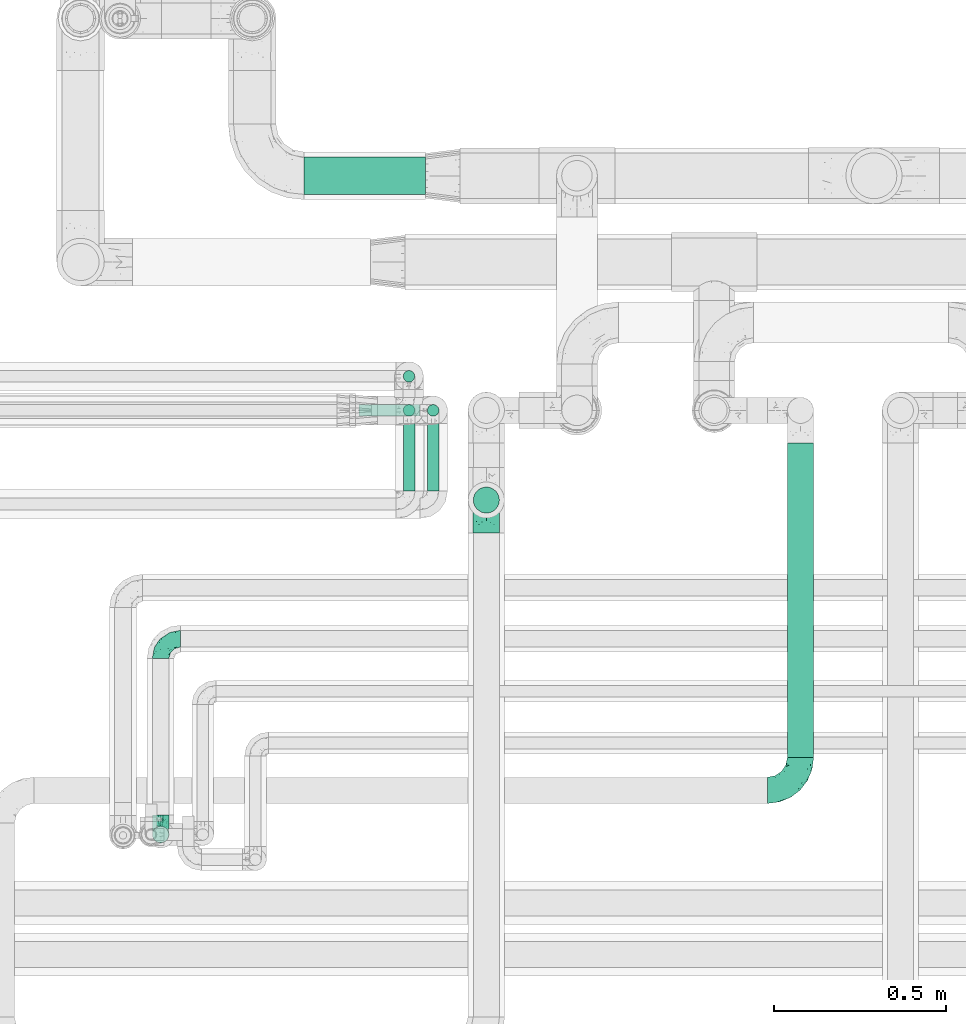
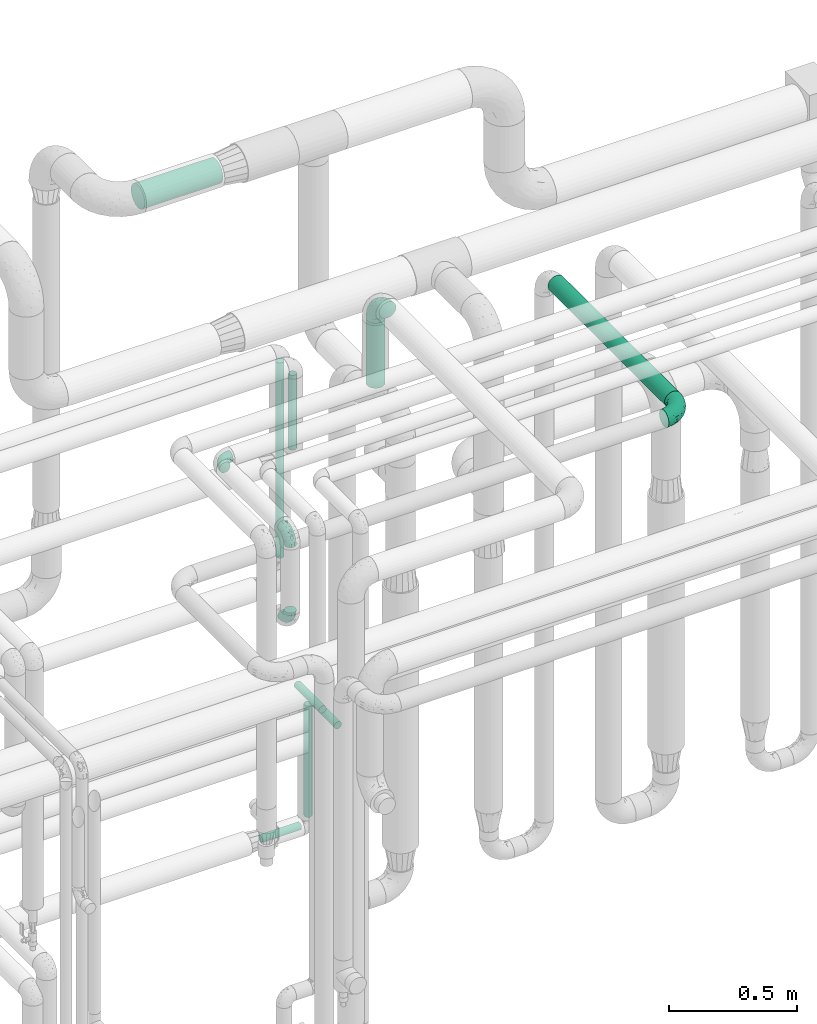
# One storey, part 703 of 827: 9 flow segments, 5 flow fittings.
"""IFC2X3 building model written with IfcOpenShell, lengths in millimetres."""

from ifc_helpers import new_model, entity, si_unit, converted_unit, derived_unit, direction, frame, origin, origin_2d_with_axis, place, context, subcontext, project, spatial, circle, extrude, faceted_brep, source, transform, mapped, material, type_object, type_shapes, element, save


model = new_model("IFC2X3")

# Units and contexts
model_context = context("Model", 3, precision=0.01, world=origin(), true_north=direction((6.12303176911189e-17, 1.0)))
body_context = subcontext(model_context, "Body", "Model", "MODEL_VIEW")
ifc_project = project(units=[si_unit("LENGTHUNIT", "METRE", prefix="MILLI"), si_unit("AREAUNIT", "SQUARE_METRE"), si_unit("VOLUMEUNIT", "CUBIC_METRE"), converted_unit("PLANEANGLEUNIT", "DEGREE", entity("IfcRatioMeasure", 0.0174532925199433), si_unit("PLANEANGLEUNIT", "RADIAN"), dimensions=[0, 0, 0, 0, 0, 0, 0]), si_unit("MASSUNIT", "GRAM", prefix="KILO"), derived_unit("MASSDENSITYUNIT", [(si_unit("MASSUNIT", "GRAM", prefix="KILO"), 1), (si_unit("LENGTHUNIT", "METRE"), -3)]), derived_unit("MOMENTOFINERTIAUNIT", [(si_unit("LENGTHUNIT", "METRE"), 4)]), si_unit("TIMEUNIT", "SECOND"), si_unit("FREQUENCYUNIT", "HERTZ"), si_unit("THERMODYNAMICTEMPERATUREUNIT", "DEGREE_CELSIUS"), derived_unit("THERMALTRANSMITTANCEUNIT", [(si_unit("MASSUNIT", "GRAM", prefix="KILO"), 1), (si_unit("THERMODYNAMICTEMPERATUREUNIT", "KELVIN"), -1), (si_unit("TIMEUNIT", "SECOND"), -3)]), derived_unit("VOLUMETRICFLOWRATEUNIT", [(si_unit("LENGTHUNIT", "METRE"), 3), (si_unit("TIMEUNIT", "SECOND"), -1)]), derived_unit("MASSFLOWRATEUNIT", [(si_unit("MASSUNIT", "GRAM", prefix="KILO"), 1), (si_unit("TIMEUNIT", "SECOND"), -1)]), derived_unit("ROTATIONALFREQUENCYUNIT", [(si_unit("TIMEUNIT", "SECOND"), -1)]), si_unit("ELECTRICCURRENTUNIT", "AMPERE"), si_unit("ELECTRICVOLTAGEUNIT", "VOLT"), si_unit("POWERUNIT", "WATT"), si_unit("FORCEUNIT", "NEWTON", prefix="KILO"), si_unit("ILLUMINANCEUNIT", "LUX"), si_unit("LUMINOUSFLUXUNIT", "LUMEN"), si_unit("LUMINOUSINTENSITYUNIT", "CANDELA"), derived_unit("USERDEFINED", [(si_unit("MASSUNIT", "GRAM", prefix="KILO"), -1), (si_unit("LENGTHUNIT", "METRE"), -2), (si_unit("TIMEUNIT", "SECOND"), 3), (si_unit("LUMINOUSFLUXUNIT", "LUMEN"), 1)]), derived_unit("LINEARVELOCITYUNIT", [(si_unit("LENGTHUNIT", "METRE"), 1), (si_unit("TIMEUNIT", "SECOND"), -1)]), si_unit("PRESSUREUNIT", "PASCAL"), derived_unit("USERDEFINED", [(si_unit("LENGTHUNIT", "METRE"), -2), (si_unit("MASSUNIT", "GRAM", prefix="KILO"), 1), (si_unit("TIMEUNIT", "SECOND"), -2)]), derived_unit("LINEARFORCEUNIT", [(si_unit("MASSUNIT", "GRAM", prefix="KILO"), 1), (si_unit("LENGTHUNIT", "METRE"), 1), (si_unit("TIMEUNIT", "SECOND"), -2), (si_unit("LENGTHUNIT", "METRE"), -1)]), derived_unit("PLANARFORCEUNIT", [(si_unit("MASSUNIT", "GRAM", prefix="KILO"), 1), (si_unit("LENGTHUNIT", "METRE"), 1), (si_unit("TIMEUNIT", "SECOND"), -2), (si_unit("LENGTHUNIT", "METRE"), -2)])], contexts=[model_context])

# Site, building, storey
site_placement = place(None, origin())
site = spatial("IfcSite", under=ifc_project, at=site_placement, CompositionType="ELEMENT")
building_placement = place(site_placement, origin())
building = spatial("IfcBuilding", under=site, at=building_placement, CompositionType="ELEMENT")
storey_placement = place(building_placement, frame((0.0, 0.0, 28200.0)))
storey = spatial("IfcBuildingStorey", under=building, at=storey_placement, Name="08", CompositionType="ELEMENT", Elevation=28200.0)

# Flow segments
pipe_segment_type_1 = type_object("IfcPipeSegmentType", PredefinedType="NOTDEFINED")
flow_segment_1_placement = place(storey_placement, frame((56258.55, 18124.5, 3444.15)))
element("IfcFlowSegment", 1, at=flow_segment_1_placement, inside=storey, type_object=pipe_segment_type_1, context=body_context, shape_type="SweptSolid", body=[
    extrude(circle(Radius=54.0, at=origin_2d_with_axis()), frame((0.0, 55.6, 55.6), z_axis=(1.0, 0.0, 0.0), x_axis=(0.0, 1.0, 0.0)), (0.0, 0.0, 1.0), 352.499999999972),
])
pipe_segment_type_2 = type_object("IfcPipeSegmentType", PredefinedType="NOTDEFINED")
flow_segment_2_placement = place(storey_placement, frame((57658.79, 16493.62, 3010.65)))
element("IfcFlowSegment", 2, at=flow_segment_2_placement, inside=storey, type_object=pipe_segment_type_2, context=body_context, shape_type="SweptSolid", body=[
    extrude(circle(Radius=37.75, at=origin_2d_with_axis()), frame((39.35, 0.0, 39.35), z_axis=(0.0, 1.0, 0.0), x_axis=(-1.0, 0.0, 0.0)), (0.0, 0.0, 1.0), 911.38356635599),
])
flow_segment_3_placement = place(storey_placement, frame((56544.88, 17580.47, 2030.5)))
element("IfcFlowSegment", 3, at=flow_segment_3_placement, inside=storey, type_object=pipe_segment_type_2, context=body_context, shape_type="SweptSolid", body=[
    extrude(circle(Radius=16.75, at=origin_2d_with_axis()), frame((18.35, 18.35, 0.0)), (0.0, 0.0, 1.0), 931.586150798507),
])
flow_segment_4_placement = place(storey_placement, frame((56544.88, 17481.65, 2605.5)))
element("IfcFlowSegment", 4, at=flow_segment_4_placement, inside=storey, type_object=pipe_segment_type_2, context=body_context, shape_type="SweptSolid", body=[
    extrude(circle(Radius=16.75, at=origin_2d_with_axis()), frame((18.35, 18.35, 0.0)), (0.0, 0.0, 1.0), 356.499999999793),
])
for number, where in (
    (5, (56545.88, 17266.56, 1481.65)),
    (6, (56614.88, 17266.56, 1381.65)),
):
    element("IfcFlowSegment", number, at=place(storey_placement, frame(where)), inside=storey, type_object=pipe_segment_type_2, context=body_context, shape_type="SweptSolid", body=[
        extrude(circle(Radius=16.75, at=origin_2d_with_axis()), frame((18.35, 0.0, 18.35), z_axis=(0.0, 1.0, 0.0), x_axis=(1.0, 0.0, 0.0)), (0.0, 0.0, 1.0), 195.438135542264),
    ])
flow_segment_5_placement = place(storey_placement, frame((56614.88, 17481.65, 830.5)))
element("IfcFlowSegment", 7, at=flow_segment_5_placement, inside=storey, type_object=pipe_segment_type_2, context=body_context, shape_type="SweptSolid", body=[
    extrude(circle(Radius=16.75, at=origin_2d_with_axis()), frame((18.35, 18.35, 0.0)), (0.0, 0.0, 1.0), 531.500000000009),
])
flow_segment_6_placement = place(storey_placement, frame((56418.23, 17481.65, 774.15)))
element("IfcFlowSegment", 8, at=flow_segment_6_placement, inside=storey, type_object=pipe_segment_type_2, context=body_context, shape_type="SweptSolid", body=[
    extrude(circle(Radius=16.75, at=origin_2d_with_axis()), frame((0.0, 18.35, 18.35), z_axis=(1.0, 0.0, 0.0), x_axis=(0.0, 1.0, 0.0)), (0.0, 0.0, 1.0), 177.00000000002),
])
flow_segment_7_placement = place(storey_placement, frame((56748.04, 17200.65, 2995.0)))
element("IfcFlowSegment", 9, at=flow_segment_7_placement, inside=storey, type_object=pipe_segment_type_2, context=body_context, shape_type="SweptSolid", body=[
    extrude(circle(Radius=37.75, at=origin_2d_with_axis()), frame((39.35, 39.35, 0.0)), (0.0, 0.0, 1.0), 309.999999999999),
])

# Flow fittings
ifc_material = material()
pipe_fitting_type_1 = type_object("IfcPipeFittingType", Name="ADSK_1", PredefinedType="NOTDEFINED", material=ifc_material)
shared_shape_1 = source(origin(), body_context, "Body", "Brep", [
    faceted_brep([(-57.0, 12.07, -20.91), (-57.0, 6.25, -23.33), (-57.0, 0.0, -24.15), (-57.0, -6.25, -23.33), (-57.0, -12.08, -20.91), (-57.0, -17.08, -17.08), (-57.0, -20.91, -12.08), (-57.0, -23.33, -6.25), (-57.0, -24.15, 0.0), (-57.0, -23.33, 6.25), (-57.0, -20.91, 12.07), (-57.0, -17.08, 17.08), (-57.0, -12.08, 20.91), (-57.0, -6.25, 23.33), (-57.0, 0.0, 24.15), (-57.0, 6.25, 23.33), (-57.0, 12.07, 20.91), (-57.0, 17.08, 17.08), (-57.0, 20.91, 12.07), (-57.0, 23.33, 6.25), (-57.0, 24.15, 0.0), (-57.0, 23.33, -6.25), (-57.0, 20.91, -12.08), (-57.0, 17.08, -17.08), (0.0, 57.0, -24.15), (-6.25, 57.0, -23.33), (-12.07, 57.0, -20.91), (-17.08, 57.0, -17.08), (-20.91, 57.0, -12.08), (-23.33, 57.0, -6.25), (-24.15, 57.0, 0.0), (-23.33, 57.0, 6.25), (-20.91, 57.0, 12.07), (-17.08, 57.0, 17.08), (-12.07, 57.0, 20.91), (-6.25, 57.0, 23.33), (0.0, 57.0, 24.15), (6.25, 57.0, 23.33), (12.08, 57.0, 20.91), (17.08, 57.0, 17.08), (20.91, 57.0, 12.07), (23.33, 57.0, 6.25), (24.15, 57.0, 0.0), (23.33, 57.0, -6.25), (20.91, 57.0, -12.08), (17.08, 57.0, -17.08), (12.08, 57.0, -20.91), (6.25, 57.0, -23.33), (14.9, 21.14, 6.17), (13.61, 24.64, 12.48), (6.23, 8.95, 8.98), (-41.47, -21.06, 0.0), (-41.92, -18.38, 13.72), (-24.64, -13.61, 12.48), (-37.37, -13.24, 18.15), (-6.8, -4.93, 8.18), (-21.76, -15.19, 6.22), (-12.78, -9.18, 0.0), (-37.73, -20.51, 7.75), (-7.38, 7.38, 20.24), (-23.37, -4.26, 20.42), (-11.9, -3.19, 15.86), (-42.14, -8.7, 21.82), (13.24, 37.37, 18.15), (9.33, 23.53, 16.85), (4.26, 23.37, 20.42), (2.77, 10.92, 15.55), (-29.46, 0.91, 23.52), (-44.13, 20.56, 15.69), (-39.25, 26.33, 10.88), (-49.02, 22.92, 9.96), (-34.58, 23.87, 17.15), (-15.8, 6.8, 22.81), (-8.67, 20.47, 23.88), (-18.12, 12.9, 24.08), (-48.29, 14.92, 19.65), (-44.06, -2.85, 23.78), (-9.23, 48.95, 22.58), (-3.78, 42.74, 24.07), (-40.34, 4.26, 24.09), (-44.02, 26.14, 5.46), (-44.04, 9.88, 22.74), (-4.95, 16.87, 22.52), (-2.75, 1.43, 12.5), (-25.48, 40.98, 10.71), (20.51, 37.73, 7.75), (18.38, 41.92, 13.72), (8.7, 42.14, 21.82), (-25.95, -17.97, 0.0), (2.85, 44.06, 23.78), (21.06, 41.47, 0.0), (17.97, 25.95, 0.0), (-24.04, -9.27, 17.13), (-33.26, 33.26, 5.86), (-28.55, 40.57, 0.0), (-40.57, 28.55, 0.0), (-25.29, 47.19, 4.06), (-27.01, 31.1, 16.77), (-15.7, 43.95, 19.9), (-20.27, 45.22, 15.61), (-30.53, 31.98, 12.64), (-11.28, 38.33, 22.92), (-9.97, 27.88, 24.09), (-20.15, 30.26, 21.25), (-31.25, 11.75, 23.64), (-28.75, 7.23, 24.15), (-29.53, 18.06, 22.27), (-28.44, 24.21, 20.02), (-37.55, 17.7, 20.26), (-15.88, 29.25, 22.99), (-20.82, 20.82, 23.44), (-0.91, 29.46, 23.52), (-13.5, -7.67, 12.04), (1.49, 1.56, 5.16), (8.86, 10.35, 4.59), (0.38, -0.38, 0.0), (9.18, 12.78, 0.0), (-37.37, -13.24, -18.15), (8.86, 10.35, -4.59), (-45.22, 20.27, -15.61), (-43.95, 15.7, -19.9), (-38.33, 11.28, -22.92), (-48.95, 9.23, -22.58), (-47.19, 25.29, -4.06), (-33.26, 33.26, -5.86), (18.38, 41.92, -13.72), (-30.26, 20.15, -21.25), (2.85, 44.06, -23.78), (-4.26, 40.34, -24.09), (-40.98, 25.48, -10.71), (-41.92, -18.38, -13.72), (9.25, 23.5, -16.92), (4.26, 23.37, -20.42), (13.24, 37.37, -18.15), (-37.73, -20.51, -7.75), (-11.75, 31.25, -23.64), (-7.23, 28.75, -24.15), (-12.9, 18.12, -24.08), (8.7, 42.14, -21.82), (-44.06, -2.85, -23.78), (-6.8, 15.8, -22.81), (-20.47, 8.67, -23.88), (-24.64, -13.61, -12.48), (-42.74, 3.78, -24.07), (-18.06, 29.53, -22.27), (-24.21, 28.44, -20.02), (-27.88, 9.97, -24.09), (-31.1, 27.01, -16.77), (-26.14, 44.02, -5.46), (14.9, 21.14, -6.17), (20.51, 37.73, -7.75), (-9.88, 44.04, -22.74), (-20.56, 44.13, -15.69), (-21.76, -15.19, -6.22), (-13.5, -7.67, -12.04), (-24.14, -9.76, -16.74), (-11.9, -3.19, -15.86), (-14.92, 48.29, -19.65), (-23.37, -4.26, -20.42), (-0.91, 29.46, -23.52), (-26.33, 39.25, -10.88), (-23.87, 34.58, -17.15), (-42.14, -8.7, -21.82), (-22.92, 49.02, -9.96), (13.61, 24.64, -12.48), (-31.98, 30.53, -12.64), (-16.87, 4.95, -22.52), (-17.7, 37.55, -20.26), (-29.25, 15.88, -22.99), (-20.82, 20.82, -23.44), (-29.46, 0.91, -23.52), (-7.38, 7.38, -20.24), (2.77, 10.92, -15.55), (6.23, 8.95, -8.98), (-6.8, -4.93, -8.18), (-2.81, 1.41, -12.54), (1.49, 1.56, -5.16)], [[[0, 1, 2, 3, 4, 5, 6, 7, 8, 9, 10, 11, 12, 13, 14, 15, 16, 17, 18, 19, 20, 21, 22, 23]], [[24, 25, 26, 27, 28, 29, 30, 31, 32, 33, 34, 35, 36, 37, 38, 39, 40, 41, 42, 43, 44, 45, 46, 47]], [[48, 49, 50]], [[9, 8, 51]], [[52, 53, 54]], [[55, 56, 57]], [[10, 58, 52]], [[9, 58, 10]], [[59, 60, 61]], [[54, 12, 11]], [[54, 62, 12]], [[63, 39, 38]], [[64, 65, 66]], [[62, 60, 67]], [[68, 69, 70]], [[71, 69, 68]], [[72, 73, 74]], [[16, 75, 17]], [[13, 76, 14]], [[35, 77, 78]], [[14, 79, 15]], [[17, 68, 18]], [[14, 76, 79]], [[20, 19, 80]], [[70, 19, 18]], [[81, 15, 79]], [[15, 81, 16]], [[73, 72, 82]], [[66, 83, 50]], [[32, 31, 84]], [[85, 86, 49]], [[63, 87, 65]], [[56, 58, 88]], [[36, 89, 37]], [[85, 41, 40]], [[36, 35, 78]], [[90, 41, 85]], [[40, 39, 86]], [[12, 62, 13]], [[86, 85, 40]], [[48, 85, 49]], [[85, 91, 90]], [[87, 38, 37]], [[92, 60, 54]], [[80, 69, 93]], [[93, 94, 95]], [[10, 52, 11]], [[94, 96, 30]], [[97, 98, 99]], [[80, 93, 95]], [[100, 97, 84]], [[99, 98, 33]], [[101, 102, 78]], [[103, 101, 98]], [[96, 31, 30]], [[77, 98, 101]], [[77, 35, 34]], [[34, 33, 98]], [[9, 51, 58]], [[87, 63, 38]], [[104, 105, 74]], [[106, 103, 107]], [[106, 81, 104]], [[75, 68, 17]], [[108, 107, 71]], [[33, 32, 99]], [[109, 103, 110]], [[101, 109, 102]], [[89, 78, 111]], [[53, 52, 58]], [[54, 11, 52]], [[60, 62, 54]], [[88, 58, 51]], [[76, 62, 67]], [[53, 112, 92]], [[60, 59, 72]], [[39, 63, 86]], [[49, 86, 63]], [[89, 87, 37]], [[42, 41, 90]], [[111, 82, 65]], [[111, 65, 87]], [[65, 59, 66]], [[104, 81, 79]], [[75, 81, 108]], [[32, 84, 99]], [[97, 99, 84]], [[98, 97, 103]], [[106, 107, 108]], [[74, 102, 110]], [[111, 78, 102]], [[74, 110, 104]], [[74, 67, 72]], [[61, 92, 112]], [[66, 59, 61]], [[56, 53, 58]], [[66, 50, 49]], [[61, 112, 83]], [[66, 49, 64]], [[78, 89, 36]], [[87, 89, 111]], [[62, 76, 13]], [[79, 76, 67]], [[100, 93, 69]], [[96, 93, 84]], [[55, 113, 50]], [[113, 114, 50]], [[104, 79, 105]], [[106, 104, 110]], [[20, 80, 95]], [[85, 48, 91]], [[115, 114, 113]], [[116, 91, 48]], [[70, 80, 19]], [[93, 96, 94]], [[84, 31, 96]], [[103, 106, 110]], [[81, 106, 108]], [[103, 97, 107]], [[71, 107, 97]], [[71, 97, 100]], [[108, 71, 68]], [[79, 67, 105]], [[67, 74, 105]], [[115, 113, 57]], [[112, 56, 55]], [[56, 88, 57]], [[60, 72, 67]], [[82, 72, 59]], [[65, 82, 59]], [[82, 111, 73]], [[111, 102, 73]], [[102, 74, 73]], [[81, 75, 16]], [[68, 75, 108]], [[68, 70, 18]], [[80, 70, 69]], [[98, 77, 34]], [[78, 77, 101]], [[93, 100, 84]], [[71, 100, 69]], [[102, 109, 110]], [[101, 103, 109]], [[53, 92, 54]], [[61, 60, 92]], [[56, 112, 53]], [[83, 112, 55]], [[50, 83, 55]], [[61, 83, 66]], [[49, 63, 64]], [[65, 64, 63]], [[57, 113, 55]], [[114, 115, 116]], [[116, 48, 114]], [[48, 50, 114]], [[117, 5, 4]], [[116, 115, 118]], [[119, 120, 23]], [[121, 122, 120]], [[95, 123, 20]], [[0, 23, 120]], [[124, 95, 94]], [[125, 45, 44]], [[121, 120, 126]], [[24, 127, 128]], [[22, 21, 129]], [[0, 122, 1]], [[5, 117, 130]], [[131, 132, 133]], [[134, 88, 51]], [[135, 136, 137]], [[6, 5, 130]], [[46, 138, 47]], [[139, 3, 2]], [[140, 141, 137]], [[6, 134, 7]], [[134, 130, 142]], [[143, 2, 1]], [[144, 126, 145]], [[121, 146, 143]], [[147, 120, 119]], [[94, 148, 124]], [[149, 150, 91]], [[30, 29, 148]], [[151, 25, 128]], [[27, 152, 28]], [[134, 153, 88]], [[154, 155, 156]], [[27, 26, 157]], [[151, 26, 25]], [[155, 158, 156]], [[24, 47, 127]], [[1, 122, 143]], [[138, 132, 159]], [[160, 152, 161]], [[24, 128, 25]], [[46, 133, 138]], [[162, 117, 4]], [[148, 160, 124]], [[152, 160, 163]], [[154, 142, 155]], [[45, 125, 133]], [[133, 46, 45]], [[125, 164, 133]], [[51, 7, 134]], [[42, 90, 43]], [[165, 147, 129]], [[153, 134, 142]], [[43, 150, 44]], [[162, 4, 3]], [[141, 140, 166]], [[117, 162, 158]], [[163, 29, 28]], [[43, 90, 150]], [[123, 21, 20]], [[144, 151, 135]], [[157, 152, 27]], [[167, 145, 161]], [[23, 22, 119]], [[168, 126, 169]], [[121, 168, 146]], [[139, 143, 170]], [[142, 130, 117]], [[8, 7, 51]], [[134, 6, 130]], [[139, 162, 3]], [[170, 166, 158]], [[170, 158, 162]], [[158, 171, 156]], [[44, 150, 125]], [[91, 150, 90]], [[164, 125, 150]], [[132, 138, 133]], [[127, 138, 159]], [[131, 164, 172]], [[132, 171, 140]], [[135, 151, 128]], [[157, 151, 167]], [[22, 129, 119]], [[147, 119, 129]], [[120, 147, 126]], [[144, 145, 167]], [[137, 146, 169]], [[170, 143, 146]], [[137, 169, 135]], [[137, 159, 140]], [[171, 172, 156]], [[173, 174, 175]], [[156, 175, 154]], [[174, 57, 153]], [[132, 172, 171]], [[172, 164, 173]], [[143, 139, 2]], [[162, 139, 170]], [[138, 127, 47]], [[128, 127, 159]], [[165, 124, 160]], [[123, 124, 129]], [[149, 173, 164]], [[176, 174, 173]], [[135, 128, 136]], [[144, 135, 169]], [[150, 149, 164]], [[176, 118, 115]], [[149, 91, 116]], [[30, 148, 94]], [[163, 148, 29]], [[124, 123, 95]], [[129, 21, 123]], [[126, 144, 169]], [[151, 144, 167]], [[126, 147, 145]], [[161, 145, 147]], [[161, 147, 165]], [[167, 161, 152]], [[128, 159, 136]], [[159, 137, 136]], [[154, 153, 142]], [[132, 140, 159]], [[174, 176, 57]], [[57, 88, 153]], [[166, 140, 171]], [[158, 166, 171]], [[166, 170, 141]], [[170, 146, 141]], [[146, 137, 141]], [[151, 157, 26]], [[152, 157, 167]], [[152, 163, 28]], [[148, 163, 160]], [[120, 122, 0]], [[143, 122, 121]], [[124, 165, 129]], [[161, 165, 160]], [[146, 168, 169]], [[121, 126, 168]], [[142, 117, 155]], [[158, 155, 117]], [[175, 156, 172]], [[153, 154, 174]], [[173, 175, 172]], [[174, 154, 175]], [[164, 131, 133]], [[172, 132, 131]], [[176, 173, 118]], [[57, 176, 115]], [[173, 149, 118]], [[149, 116, 118]]]),
])
type_shapes(pipe_fitting_type_1, [shared_shape_1])
for number, where, z_axis, x_axis, name in (
    (10, (55843.13, 16837.94, 3200.0), (0.0, 0.0, 1.0), (-1.0, 0.0, 0.0), "ADSK_1"),
    (11, (55843.13, 16270.44, 3200.0), (1.0, 0.0, 0.0), (0.0, -1.0, 0.0), "ADSK_1"),
    (12, (55843.13, 16270.44, 2775.0), (1.0, 0.0, 0.0), (0.0, 0.0, -1.0), "ADSK_1"),
):
    element("IfcFlowFitting", number, at=place(storey_placement, frame(where, z_axis=z_axis, x_axis=x_axis)), inside=storey, type_object=pipe_fitting_type_1, material=ifc_material, Name=name, ObjectType="ADSK_1", context=body_context, shape_type="MappedRepresentation", body=[
        mapped(shared_shape_1, transform((0.0, 0.0, 0.0), scale=1.0)),
    ])
pipe_fitting_type_2 = type_object("IfcPipeFittingType", Name="ADSK_1", PredefinedType="NOTDEFINED", material=ifc_material)
shared_shape_2 = source(origin(), body_context, "Body", "Brep", [
    faceted_brep([(-95.0, 19.02, -32.95), (-95.0, 9.85, -36.75), (-95.0, 0.0, -38.05), (-95.0, -9.85, -36.75), (-95.0, -19.03, -32.95), (-95.0, -26.91, -26.91), (-95.0, -32.95, -19.03), (-95.0, -36.75, -9.85), (-95.0, -38.05, 0.0), (-95.0, -36.75, 9.85), (-95.0, -32.95, 19.02), (-95.0, -26.91, 26.91), (-95.0, -19.03, 32.95), (-95.0, -9.85, 36.75), (-95.0, 0.0, 38.05), (-95.0, 9.85, 36.75), (-95.0, 19.02, 32.95), (-95.0, 26.91, 26.91), (-95.0, 32.95, 19.02), (-95.0, 36.75, 9.85), (-95.0, 38.05, 0.0), (-95.0, 36.75, -9.85), (-95.0, 32.95, -19.03), (-95.0, 26.91, -26.91), (0.0, 95.0, -38.05), (-9.85, 95.0, -36.75), (-19.02, 95.0, -32.95), (-26.91, 95.0, -26.91), (-32.95, 95.0, -19.03), (-36.75, 95.0, -9.85), (-38.05, 95.0, 0.0), (-36.75, 95.0, 9.85), (-32.95, 95.0, 19.02), (-26.91, 95.0, 26.91), (-19.02, 95.0, 32.95), (-9.85, 95.0, 36.75), (0.0, 95.0, 38.05), (9.85, 95.0, 36.75), (19.03, 95.0, 32.95), (26.91, 95.0, 26.91), (32.95, 95.0, 19.02), (36.75, 95.0, 9.85), (38.05, 95.0, 0.0), (36.75, 95.0, -9.85), (32.95, 95.0, -19.03), (26.91, 95.0, -26.91), (19.03, 95.0, -32.95), (9.85, 95.0, -36.75), (-7.99, -4.96, 6.3), (-0.92, 0.92, 0.0), (4.62, 8.1, 8.01), (-76.19, -35.57, 0.0), (-64.32, -32.32, 12.43), (20.51, 62.45, 28.68), (-60.56, -33.52, 0.0), (-70.4, -13.47, 34.42), (-39.61, -5.88, 32.32), (-49.6, 2.07, 37.1), (-70.34, -28.81, 21.71), (14.64, 40.81, 26.5), (5.88, 39.61, 32.32), (3.59, 20.77, 25.31), (-40.45, 68.06, 16.75), (-62.45, -20.51, 28.68), (-44.52, -26.87, 0.0), (-28.47, -20.22, 0.0), (-26.43, -17.83, 8.75), (-76.1, 39.63, 10.76), (-72.74, 37.58, 18.19), (-60.35, 46.18, 14.61), (-13.4, 13.4, 32.12), (-20.77, -3.59, 25.31), (-14.66, 81.47, 35.56), (-6.22, 71.26, 37.92), (-57.5, 42.48, 22.79), (-15.0, 34.74, 37.7), (-27.1, 12.08, 36.05), (-9.2, 28.81, 35.63), (-79.98, 23.7, 30.95), (-73.68, -4.3, 37.48), (-30.74, 21.67, 37.97), (-62.36, 47.59, 6.79), (-72.71, 32.83, 24.69), (-67.42, 7.02, 37.95), (-32.13, 75.27, 24.51), (-43.46, 51.47, 26.26), (-24.98, 73.15, 31.29), (20.59, 41.28, 19.85), (7.79, 16.09, 15.86), (-73.21, 42.39, 0.0), (-54.73, 54.73, 0.0), (-73.44, 15.79, 35.79), (-5.94, 4.32, 20.43), (28.81, 70.34, 21.71), (32.32, 64.32, 12.43), (-53.59, 26.2, 35.09), (-52.02, 19.31, 37.21), (21.38, 33.53, 10.34), (26.87, 44.52, 0.0), (-48.28, 12.14, 38.05), (4.3, 73.68, 37.48), (-44.08, -25.52, 12.79), (-41.28, -20.59, 19.85), (35.57, 76.19, 0.0), (-47.26, 54.3, 20.18), (-47.4, 61.99, 8.58), (-42.39, 73.21, 0.0), (-39.67, 78.86, 7.21), (-45.69, 36.84, 33.11), (-32.83, 50.13, 33.35), (13.47, 70.4, 34.42), (-18.25, 63.73, 36.07), (-40.63, -13.75, 27.22), (-16.63, 46.37, 37.95), (-53.47, 38.79, 28.59), (-26.07, 48.54, 36.15), (-34.51, 34.51, 36.86), (-2.07, 49.6, 37.1), (-22.79, -10.49, 19.23), (-61.73, 28.67, 31.87), (9.65, 14.7, 0.0), (20.22, 28.47, 0.0), (33.52, 60.56, 0.0), (-11.42, -5.44, 13.25), (-14.7, -9.65, 0.0), (-81.47, 14.66, -35.56), (-62.45, -20.51, -28.68), (-71.26, 6.22, -37.92), (-75.27, 32.13, -24.51), (-73.15, 24.98, -31.29), (13.47, 70.4, -34.42), (5.88, 39.61, -32.32), (-2.07, 49.6, -37.1), (-78.86, 39.67, -7.21), (-70.4, -13.47, -34.42), (-39.61, -5.88, -32.32), (-61.99, 47.4, -8.58), (32.32, 64.32, -12.43), (28.81, 70.34, -21.71), (-63.73, 18.25, -36.07), (-50.13, 32.83, -33.35), (4.3, 73.68, -37.48), (-7.02, 67.42, -37.95), (-39.63, 76.1, -10.76), (-46.18, 60.35, -14.61), (-47.59, 62.36, -6.79), (-64.32, -32.32, -12.43), (-26.2, 53.59, -35.09), (-15.79, 73.44, -35.79), (-19.31, 52.02, -37.21), (-37.58, 72.74, -18.19), (-70.34, -28.81, -21.71), (-42.48, 57.5, -22.79), (-38.79, 53.47, -28.59), (-51.47, 43.46, -26.26), (-32.83, 72.71, -24.69), (-46.37, 16.63, -37.95), (-73.68, -4.3, -37.48), (-41.28, -20.59, -19.85), (-44.08, -25.52, -12.79), (13.75, 40.63, -27.22), (20.51, 62.45, -28.68), (-68.06, 40.45, -16.75), (-54.3, 47.26, -20.18), (-12.14, 48.28, -38.05), (-21.67, 30.74, -37.97), (-36.84, 45.69, -33.11), (-11.42, -5.44, -13.25), (7.79, 16.09, -15.86), (4.62, 8.1, -8.01), (-23.7, 79.98, -30.95), (-26.43, -17.83, -8.75), (-7.99, -4.96, -6.3), (-40.81, -14.64, -26.5), (-20.77, -3.59, -25.31), (-34.74, 15.0, -37.7), (-12.08, 27.1, -36.05), (-28.81, 9.2, -35.63), (-22.79, -10.49, -19.23), (21.38, 33.53, -10.34), (20.59, 41.28, -19.85), (-48.54, 26.07, -36.15), (-49.6, 2.07, -37.1), (-13.4, 13.4, -32.12), (3.59, 20.77, -25.31), (-28.67, 61.73, -31.87), (-34.51, 34.51, -36.86), (-5.94, 4.32, -20.43)], [[[0, 1, 2, 3, 4, 5, 6, 7, 8, 9, 10, 11, 12, 13, 14, 15, 16, 17, 18, 19, 20, 21, 22, 23]], [[24, 25, 26, 27, 28, 29, 30, 31, 32, 33, 34, 35, 36, 37, 38, 39, 40, 41, 42, 43, 44, 45, 46, 47]], [[48, 49, 50]], [[51, 52, 9]], [[53, 39, 38]], [[9, 52, 10]], [[54, 52, 51]], [[55, 56, 57]], [[11, 10, 58]], [[59, 60, 61]], [[32, 31, 62]], [[63, 12, 11]], [[63, 55, 12]], [[64, 65, 66]], [[67, 68, 69]], [[70, 56, 71]], [[35, 72, 73]], [[69, 68, 74]], [[75, 76, 77]], [[16, 78, 17]], [[13, 79, 14]], [[76, 75, 80]], [[67, 69, 81]], [[18, 17, 82]], [[14, 79, 83]], [[20, 19, 67]], [[84, 85, 86]], [[87, 61, 88]], [[89, 81, 90]], [[18, 82, 68]], [[15, 91, 16]], [[14, 83, 15]], [[71, 92, 61]], [[17, 78, 82]], [[93, 87, 94]], [[95, 91, 96]], [[97, 98, 94]], [[86, 72, 34]], [[96, 99, 80]], [[37, 36, 100]], [[40, 39, 93]], [[40, 94, 41]], [[64, 66, 101]], [[93, 94, 40]], [[58, 102, 63]], [[94, 103, 41]], [[94, 87, 97]], [[104, 69, 74]], [[34, 33, 86]], [[105, 69, 104]], [[52, 58, 10]], [[106, 107, 30]], [[108, 109, 85]], [[105, 106, 90]], [[53, 110, 60]], [[86, 111, 72]], [[86, 109, 111]], [[33, 84, 86]], [[12, 55, 13]], [[112, 56, 63]], [[110, 38, 37]], [[34, 72, 35]], [[36, 35, 73]], [[111, 113, 73]], [[105, 107, 106]], [[110, 53, 38]], [[74, 114, 85]], [[91, 15, 83]], [[105, 90, 81]], [[107, 62, 31]], [[33, 32, 84]], [[115, 109, 116]], [[111, 115, 113]], [[100, 73, 117]], [[56, 55, 63]], [[79, 55, 57]], [[102, 118, 112]], [[56, 70, 76]], [[100, 110, 37]], [[117, 77, 60]], [[117, 60, 110]], [[60, 70, 61]], [[58, 52, 101]], [[63, 11, 58]], [[39, 53, 93]], [[87, 93, 53]], [[96, 91, 83]], [[78, 91, 119]], [[32, 62, 84]], [[84, 62, 104]], [[86, 85, 109]], [[85, 114, 108]], [[80, 113, 116]], [[117, 73, 113]], [[80, 116, 96]], [[80, 57, 76]], [[71, 112, 118]], [[61, 87, 59]], [[62, 107, 105]], [[97, 120, 121]], [[70, 71, 61]], [[71, 118, 92]], [[73, 100, 36]], [[110, 100, 117]], [[55, 79, 13]], [[83, 79, 57]], [[96, 83, 99]], [[116, 108, 95]], [[50, 97, 88]], [[97, 87, 88]], [[50, 49, 120]], [[122, 94, 98]], [[89, 20, 67]], [[105, 81, 69]], [[89, 67, 81]], [[68, 19, 18]], [[68, 67, 19]], [[74, 68, 82]], [[114, 82, 119]], [[74, 85, 104]], [[82, 114, 74]], [[114, 119, 108]], [[95, 108, 119]], [[116, 109, 108]], [[123, 48, 50]], [[97, 50, 120]], [[123, 50, 88]], [[91, 95, 119]], [[116, 95, 96]], [[84, 104, 85]], [[104, 62, 105]], [[83, 57, 99]], [[57, 80, 99]], [[66, 48, 123]], [[66, 124, 48]], [[118, 66, 123]], [[124, 66, 65]], [[66, 118, 101]], [[54, 64, 52]], [[124, 49, 48]], [[30, 107, 31]], [[91, 78, 16]], [[82, 78, 119]], [[56, 76, 57]], [[77, 76, 70]], [[60, 77, 70]], [[77, 117, 75]], [[117, 113, 75]], [[113, 80, 75]], [[9, 8, 51]], [[103, 94, 122]], [[103, 42, 41]], [[73, 72, 111]], [[113, 115, 116]], [[111, 109, 115]], [[102, 112, 63]], [[71, 56, 112]], [[118, 102, 101]], [[92, 123, 88]], [[123, 92, 118]], [[61, 92, 88]], [[87, 53, 59]], [[60, 59, 53]], [[97, 121, 98]], [[58, 101, 102]], [[64, 101, 52]], [[125, 1, 0]], [[126, 5, 4]], [[2, 1, 127]], [[1, 125, 127]], [[128, 129, 23]], [[130, 131, 132]], [[89, 133, 20]], [[126, 134, 135]], [[136, 89, 90]], [[137, 138, 44]], [[139, 129, 140]], [[24, 141, 142]], [[143, 144, 145]], [[125, 129, 139]], [[6, 146, 7]], [[147, 148, 149]], [[146, 51, 7]], [[143, 150, 144]], [[146, 6, 151]], [[152, 153, 154]], [[126, 4, 134]], [[0, 23, 129]], [[28, 155, 150]], [[43, 42, 103]], [[54, 146, 64]], [[139, 156, 127]], [[157, 3, 2]], [[151, 158, 159]], [[160, 131, 161]], [[22, 21, 162]], [[136, 144, 163]], [[149, 164, 165]], [[24, 142, 25]], [[166, 140, 154]], [[154, 129, 128]], [[143, 30, 29]], [[167, 168, 169]], [[155, 28, 27]], [[26, 170, 27]], [[171, 167, 172]], [[26, 25, 148]], [[27, 170, 155]], [[173, 135, 174]], [[144, 150, 152]], [[175, 176, 177]], [[24, 47, 141]], [[45, 161, 46]], [[148, 25, 142]], [[176, 175, 165]], [[64, 159, 171]], [[138, 45, 44]], [[130, 46, 161]], [[137, 44, 43]], [[178, 159, 158]], [[137, 103, 122]], [[163, 144, 152]], [[136, 133, 89]], [[103, 137, 43]], [[6, 5, 151]], [[178, 158, 173]], [[134, 4, 3]], [[178, 173, 174]], [[137, 98, 179]], [[145, 90, 106]], [[138, 180, 161]], [[46, 130, 47]], [[136, 90, 145]], [[133, 162, 21]], [[23, 22, 128]], [[139, 140, 181]], [[139, 181, 156]], [[157, 127, 182]], [[157, 134, 3]], [[182, 177, 135]], [[182, 135, 134]], [[135, 183, 174]], [[131, 130, 161]], [[141, 130, 132]], [[160, 180, 184]], [[131, 183, 176]], [[5, 126, 151]], [[158, 151, 126]], [[180, 138, 137]], [[161, 45, 138]], [[149, 148, 142]], [[170, 148, 185]], [[22, 162, 128]], [[128, 162, 163]], [[129, 154, 140]], [[154, 153, 166]], [[165, 156, 186]], [[182, 127, 156]], [[165, 186, 149]], [[165, 132, 176]], [[131, 184, 183]], [[187, 167, 178]], [[184, 168, 187]], [[167, 169, 172]], [[184, 180, 168]], [[174, 183, 184]], [[127, 157, 2]], [[134, 157, 182]], [[130, 141, 47]], [[142, 141, 132]], [[149, 142, 164]], [[186, 166, 147]], [[180, 179, 168]], [[169, 179, 120]], [[137, 179, 180]], [[179, 121, 120]], [[106, 30, 143]], [[136, 145, 144]], [[106, 143, 145]], [[150, 29, 28]], [[150, 143, 29]], [[152, 150, 155]], [[153, 155, 185]], [[152, 154, 163]], [[155, 153, 152]], [[153, 185, 166]], [[147, 166, 185]], [[186, 140, 166]], [[169, 120, 49]], [[169, 49, 172]], [[179, 169, 168]], [[148, 147, 185]], [[186, 147, 149]], [[128, 163, 154]], [[163, 162, 136]], [[142, 132, 164]], [[132, 165, 164]], [[171, 124, 65]], [[124, 171, 172]], [[64, 146, 159]], [[171, 159, 178]], [[171, 65, 64]], [[172, 49, 124]], [[162, 133, 136]], [[20, 133, 21]], [[148, 170, 26]], [[155, 170, 185]], [[131, 176, 132]], [[177, 176, 183]], [[135, 177, 183]], [[177, 182, 175]], [[182, 156, 175]], [[156, 165, 175]], [[51, 146, 54]], [[51, 8, 7]], [[129, 125, 0]], [[127, 125, 139]], [[140, 186, 181]], [[156, 181, 186]], [[158, 126, 173]], [[135, 173, 126]], [[187, 178, 174]], [[171, 178, 167]], [[184, 187, 174]], [[167, 187, 168]], [[180, 160, 161]], [[184, 131, 160]], [[98, 137, 122]], [[98, 121, 179]], [[151, 159, 146]]]),
])
type_shapes(pipe_fitting_type_2, [shared_shape_2])
flow_fitting_1_placement = place(storey_placement, frame((57698.13, 16398.62, 3050.0)))
element("IfcFlowFitting", 13, at=flow_fitting_1_placement, inside=storey, type_object=pipe_fitting_type_2, material=ifc_material, Name="ADSK_1", ObjectType="ADSK_1", context=body_context, shape_type="MappedRepresentation", body=[
    mapped(shared_shape_2, transform((0.0, 0.0, 0.0), scale=1.0)),
])
flow_fitting_2_placement = place(storey_placement, frame((56787.39, 17240.0, 3400.0), z_axis=(1.0, 0.0, 0.0), x_axis=(0.0, 0.0, 1.0)))
element("IfcFlowFitting", 14, at=flow_fitting_2_placement, inside=storey, type_object=pipe_fitting_type_2, material=ifc_material, Name="ADSK_1", ObjectType="ADSK_1", context=body_context, shape_type="MappedRepresentation", body=[
    mapped(shared_shape_2, transform((0.0, 0.0, 0.0), scale=1.0)),
])

save(model, "model.ifc")
